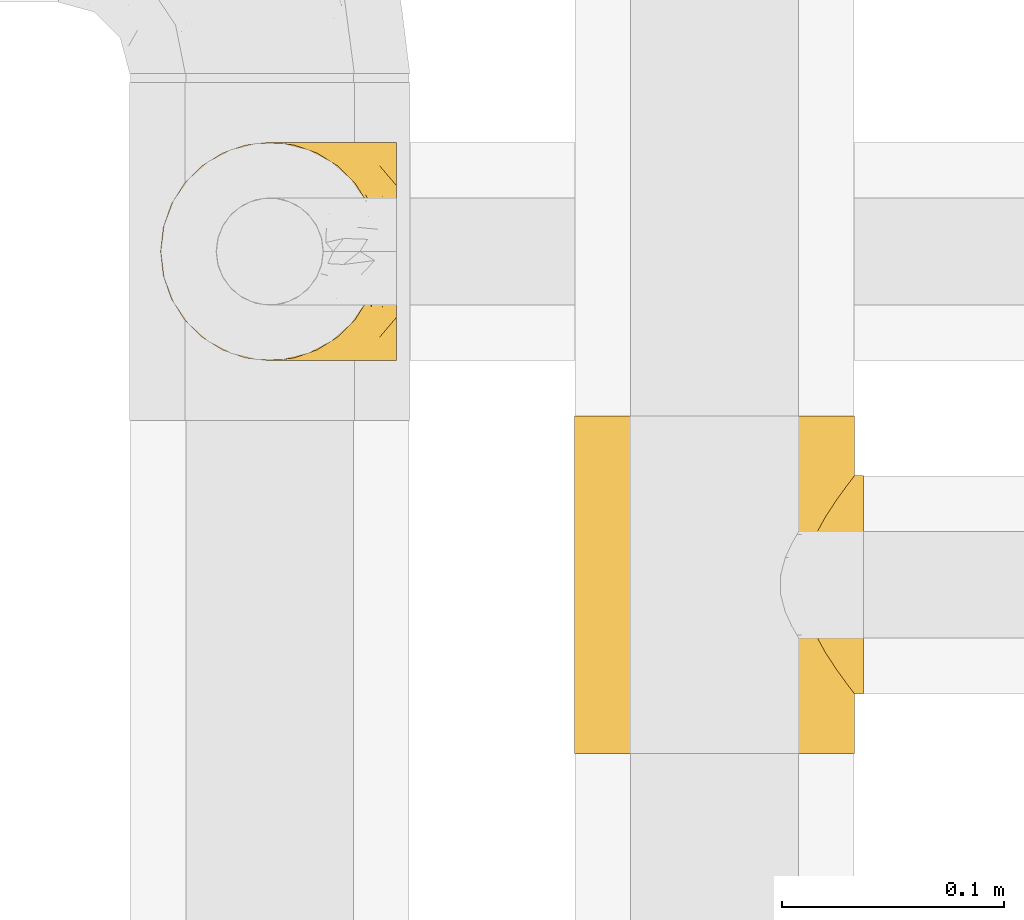
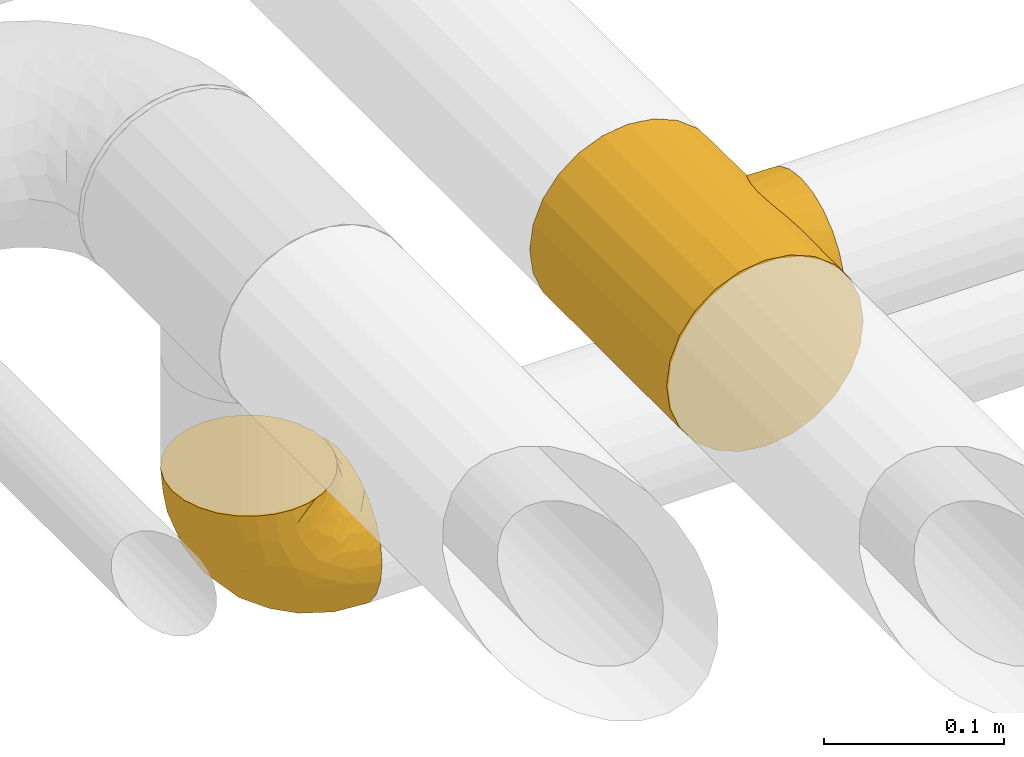
# One storey, part 404 of 827: 2 coverings.
"""IFC2X3 building model written with IfcOpenShell, lengths in millimetres."""

from ifc_helpers import new_model, entity, si_unit, converted_unit, derived_unit, direction, frame, origin, place, context, subcontext, project, spatial, faceted_brep, element, save


model = new_model("IFC2X3")

# Units and contexts
model_context = context("Model", 3, precision=0.01, world=origin(), true_north=direction((6.12303176911189e-17, 1.0)))
body_context = subcontext(model_context, "Body", "Model", "MODEL_VIEW")
ifc_project = project(units=[si_unit("LENGTHUNIT", "METRE", prefix="MILLI"), si_unit("AREAUNIT", "SQUARE_METRE"), si_unit("VOLUMEUNIT", "CUBIC_METRE"), converted_unit("PLANEANGLEUNIT", "DEGREE", entity("IfcRatioMeasure", 0.0174532925199433), si_unit("PLANEANGLEUNIT", "RADIAN"), dimensions=[0, 0, 0, 0, 0, 0, 0]), si_unit("MASSUNIT", "GRAM", prefix="KILO"), derived_unit("MASSDENSITYUNIT", [(si_unit("MASSUNIT", "GRAM", prefix="KILO"), 1), (si_unit("LENGTHUNIT", "METRE"), -3)]), derived_unit("MOMENTOFINERTIAUNIT", [(si_unit("LENGTHUNIT", "METRE"), 4)]), si_unit("TIMEUNIT", "SECOND"), si_unit("FREQUENCYUNIT", "HERTZ"), si_unit("THERMODYNAMICTEMPERATUREUNIT", "DEGREE_CELSIUS"), derived_unit("THERMALTRANSMITTANCEUNIT", [(si_unit("MASSUNIT", "GRAM", prefix="KILO"), 1), (si_unit("THERMODYNAMICTEMPERATUREUNIT", "KELVIN"), -1), (si_unit("TIMEUNIT", "SECOND"), -3)]), derived_unit("VOLUMETRICFLOWRATEUNIT", [(si_unit("LENGTHUNIT", "METRE"), 3), (si_unit("TIMEUNIT", "SECOND"), -1)]), derived_unit("MASSFLOWRATEUNIT", [(si_unit("MASSUNIT", "GRAM", prefix="KILO"), 1), (si_unit("TIMEUNIT", "SECOND"), -1)]), derived_unit("ROTATIONALFREQUENCYUNIT", [(si_unit("TIMEUNIT", "SECOND"), -1)]), si_unit("ELECTRICCURRENTUNIT", "AMPERE"), si_unit("ELECTRICVOLTAGEUNIT", "VOLT"), si_unit("POWERUNIT", "WATT"), si_unit("FORCEUNIT", "NEWTON", prefix="KILO"), si_unit("ILLUMINANCEUNIT", "LUX"), si_unit("LUMINOUSFLUXUNIT", "LUMEN"), si_unit("LUMINOUSINTENSITYUNIT", "CANDELA"), derived_unit("USERDEFINED", [(si_unit("MASSUNIT", "GRAM", prefix="KILO"), -1), (si_unit("LENGTHUNIT", "METRE"), -2), (si_unit("TIMEUNIT", "SECOND"), 3), (si_unit("LUMINOUSFLUXUNIT", "LUMEN"), 1)]), derived_unit("LINEARVELOCITYUNIT", [(si_unit("LENGTHUNIT", "METRE"), 1), (si_unit("TIMEUNIT", "SECOND"), -1)]), si_unit("PRESSUREUNIT", "PASCAL"), derived_unit("USERDEFINED", [(si_unit("LENGTHUNIT", "METRE"), -2), (si_unit("MASSUNIT", "GRAM", prefix="KILO"), 1), (si_unit("TIMEUNIT", "SECOND"), -2)]), derived_unit("LINEARFORCEUNIT", [(si_unit("MASSUNIT", "GRAM", prefix="KILO"), 1), (si_unit("LENGTHUNIT", "METRE"), 1), (si_unit("TIMEUNIT", "SECOND"), -2), (si_unit("LENGTHUNIT", "METRE"), -1)]), derived_unit("PLANARFORCEUNIT", [(si_unit("MASSUNIT", "GRAM", prefix="KILO"), 1), (si_unit("LENGTHUNIT", "METRE"), 1), (si_unit("TIMEUNIT", "SECOND"), -2), (si_unit("LENGTHUNIT", "METRE"), -2)])], contexts=[model_context])

# Site, building, storey
site_placement = place(None, origin())
site = spatial("IfcSite", under=ifc_project, at=site_placement, CompositionType="ELEMENT")
building_placement = place(site_placement, origin())
building = spatial("IfcBuilding", under=site, at=building_placement, CompositionType="ELEMENT")
storey_placement = place(building_placement, frame((0.0, 0.0, 28200.0)))
storey = spatial("IfcBuildingStorey", under=building, at=storey_placement, Name="08", CompositionType="ELEMENT", Elevation=28200.0)

# Coverings
covering_1_placement = place(storey_placement, frame((48594.1, 18129.78, 2749.25)))
element("IfcCovering", 1, at=covering_1_placement, inside=storey, Name=":ADSK_", ObjectType=":ADSK_", PredefinedType="INSULATION", context=body_context, shape_type="Brep", body=[
    faceted_brep([(50.75, 99.9, 107.75), (39.8, 98.66, 107.75), (29.41, 95.02, 107.75), (20.09, 89.17, 107.75), (12.31, 81.38, 107.75), (6.46, 72.06, 107.75), (2.83, 61.68, 107.75), (1.6, 50.75, 107.75), (2.83, 39.8, 107.75), (6.47, 29.41, 107.75), (12.32, 20.09, 107.75), (20.11, 12.31, 107.75), (29.43, 6.46, 107.75), (39.81, 2.83, 107.75), (50.75, 1.6, 107.75), (56.45, 2.24, 107.75), (61.69, 2.83, 107.75), (66.88, 4.65, 107.75), (72.08, 6.47, 107.75), (81.4, 12.32, 107.75), (89.18, 20.11, 107.75), (95.03, 29.43, 107.75), (98.66, 39.81, 107.75), (99.9, 50.75, 107.75), (98.66, 61.69, 107.75), (95.02, 72.08, 107.75), (89.17, 81.4, 107.75), (81.38, 89.18, 107.75), (72.06, 95.03, 107.75), (66.87, 96.85, 107.75), (61.68, 98.66, 107.75), (56.45, 99.25, 107.75), (53.6, 99.57, 107.75), (107.75, 38.02, 98.22), (107.75, 26.17, 93.31), (107.75, 21.08, 89.4), (107.75, 15.99, 85.5), (107.75, 12.09, 80.41), (107.75, 8.18, 75.32), (107.75, 5.73, 69.39), (107.75, 3.27, 63.47), (107.75, 2.35, 56.48), (107.75, 1.97, 53.61), (107.75, 1.6, 50.75), (107.75, 3.27, 38.02), (107.75, 8.18, 26.17), (107.75, 15.99, 15.99), (107.75, 26.17, 8.18), (107.75, 38.02, 3.27), (107.75, 50.75, 1.6), (107.75, 63.47, 3.27), (107.75, 75.32, 8.18), (107.75, 85.5, 15.99), (107.75, 93.31, 26.17), (107.75, 98.22, 38.02), (107.75, 99.9, 50.75), (107.75, 99.14, 56.48), (107.75, 98.22, 63.47), (107.75, 95.77, 69.39), (107.75, 93.31, 75.32), (107.75, 89.4, 80.41), (107.75, 85.5, 85.5), (107.75, 80.41, 89.4), (107.75, 75.32, 93.31), (107.75, 63.47, 98.22), (107.75, 50.75, 99.9), (39.38, 59.31, 27.53), (49.75, 73.08, 25.32), (57.38, 63.72, 16.29), (74.94, 50.75, 6.79), (85.97, 58.64, 4.51), (95.66, 50.75, 3.51), (67.82, 76.74, 17.47), (83.09, 67.68, 7.6), (89.16, 78.92, 12.27), (37.01, 94.31, 70.89), (43.46, 98.76, 87.17), (51.79, 98.4, 67.3), (85.58, 94.57, 31.65), (62.84, 89.91, 33.58), (62.77, 96.32, 47.23), (88.17, 98.79, 43.26), (85.93, 99.9, 55.08), (91.42, 99.9, 53.99), (96.91, 99.9, 52.9), (99.62, 99.9, 52.36), (102.33, 99.9, 51.82), (82.57, 87.31, 21.5), (32.75, 95.61, 89.94), (13.79, 60.43, 60.45), (6.77, 65.24, 83.0), (16.46, 72.87, 64.79), (55.08, 99.9, 85.93), (58.17, 99.9, 81.31), (61.26, 99.9, 76.69), (64.35, 99.9, 72.06), (67.44, 99.9, 67.44), (24.18, 90.65, 88.74), (23.37, 63.14, 45.98), (49.76, 91.89, 47.13), (9.84, 75.25, 89.4), (3.51, 50.75, 95.66), (55.75, 82.18, 28.5), (42.34, 85.08, 42.81), (37.78, 76.93, 38.28), (21.87, 50.75, 45.35), (33.61, 50.75, 33.61), (17.1, 83.02, 82.57), (51.28, 99.9, 105.04), (51.82, 99.9, 102.33), (52.9, 99.9, 96.91), (53.99, 99.9, 91.42), (28.01, 87.13, 65.92), (28.99, 80.85, 53.11), (69.9, 99.17, 54.37), (6.79, 50.75, 74.94), (72.06, 99.9, 64.35), (76.69, 99.9, 61.26), (81.31, 99.9, 58.17), (45.35, 50.75, 21.87), (34.79, 67.61, 34.79), (25.72, 72.25, 48.48), (14.33, 50.75, 60.15), (60.15, 50.75, 14.33), (62.38, 98.69, 99.07), (100.57, 99.01, 60.55), (91.06, 98.79, 64.18), (97.66, 98.29, 64.36), (97.55, 68.51, 103.17), (93.65, 76.82, 101.69), (66.85, 98.54, 87.75), (61.93, 99.3, 89.38), (101.4, 83.57, 88.34), (100.07, 89.47, 82.14), (101.36, 75.76, 94.51), (95.94, 84.86, 89.64), (96.3, 75.89, 98.41), (101.98, 64.77, 99.71), (85.88, 90.83, 89.37), (78.88, 94.62, 88.21), (82.8, 90.37, 95.2), (102.58, 91.18, 79.14), (82.88, 88.65, 101.22), (88.57, 84.11, 99.41), (88.67, 91.75, 84.72), (69.08, 96.86, 97.47), (102.19, 50.75, 102.19), (100.06, 58.97, 104.02), (70.56, 98.37, 82.66), (91.07, 83.91, 95.42), (77.56, 97.52, 78.67), (96.59, 95.55, 72.69), (86.38, 98.76, 66.46), (91.79, 95.26, 75.3), (81.71, 98.04, 72.74), (94.11, 90.65, 82.93), (76.09, 93.51, 99.27), (76.91, 94.16, 93.51), (81.44, 99.1, 67.35), (101.37, 25.73, 94.51), (94.12, 10.84, 82.94), (101.41, 17.92, 88.33), (95.96, 16.64, 89.64), (96.22, 30.44, 103.62), (66.85, 2.95, 87.74), (61.94, 2.19, 89.38), (58.17, 1.6, 81.31), (69.1, 4.63, 97.47), (88.58, 17.39, 99.41), (96.91, 1.6, 52.9), (102.33, 1.6, 51.82), (105.04, 1.6, 51.28), (82.9, 12.86, 101.21), (82.82, 11.13, 95.19), (97.66, 3.2, 64.36), (96.59, 5.94, 72.69), (100.07, 12.02, 82.13), (91.79, 6.23, 75.3), (102.58, 10.31, 79.14), (76.13, 8.0, 99.28), (76.93, 7.34, 93.51), (100.57, 2.48, 60.55), (86.38, 2.73, 66.46), (90.86, 2.64, 63.96), (52.9, 1.6, 96.91), (62.39, 2.8, 99.06), (101.98, 36.71, 99.7), (91.42, 1.6, 53.99), (85.93, 1.6, 55.08), (99.49, 38.59, 103.3), (51.82, 1.6, 102.33), (52.36, 1.6, 99.62), (61.26, 1.6, 76.69), (70.56, 3.12, 82.66), (91.09, 17.59, 95.42), (64.35, 1.6, 72.06), (77.6, 3.98, 78.68), (78.89, 6.87, 88.2), (81.71, 3.45, 72.75), (88.69, 9.76, 84.74), (53.99, 1.6, 91.42), (55.08, 1.6, 85.93), (96.31, 25.62, 98.41), (85.9, 10.67, 89.37), (81.45, 2.39, 67.35), (76.69, 1.6, 61.26), (81.31, 1.6, 58.17), (72.06, 1.6, 64.35), (67.44, 1.6, 67.44), (69.6, 2.4, 54.08), (85.97, 42.85, 4.51), (82.57, 14.18, 21.5), (63.16, 11.56, 33.43), (55.81, 19.27, 28.5), (67.81, 24.75, 17.47), (49.73, 28.37, 25.36), (32.55, 5.95, 90.18), (43.23, 2.79, 86.97), (88.17, 2.71, 43.26), (57.38, 37.78, 16.29), (83.08, 33.81, 7.6), (89.16, 22.57, 12.27), (85.58, 6.92, 31.65), (16.46, 28.61, 64.79), (6.77, 36.24, 83.0), (13.8, 41.05, 60.44), (37.71, 24.55, 38.35), (34.8, 33.88, 34.8), (36.83, 7.11, 71.54), (39.38, 42.18, 27.53), (17.12, 18.46, 82.57), (24.19, 10.84, 88.74), (28.89, 20.69, 53.19), (25.69, 29.27, 48.49), (51.77, 3.1, 67.28), (45.66, 9.18, 52.32), (23.39, 38.38, 45.94), (9.85, 26.23, 89.4), (28.11, 14.34, 65.75), (62.27, 5.46, 46.73), (42.35, 16.39, 42.82)], [[[0, 1, 2, 3, 4, 5, 6, 7, 8, 9, 10, 11, 12, 13, 14, 15, 16, 17, 18, 19, 20, 21, 22, 23, 24, 25, 26, 27, 28, 29, 30, 31, 32]], [[33, 34, 35, 36, 37, 38, 39, 40, 41, 42, 43, 44, 45, 46, 47, 48, 49, 50, 51, 52, 53, 54, 55, 56, 57, 58, 59, 60, 61, 62, 63, 64, 65]], [[66, 67, 68]], [[69, 70, 71]], [[68, 72, 73]], [[73, 72, 74]], [[75, 76, 77]], [[78, 79, 80]], [[51, 50, 73]], [[81, 82, 83, 84, 85, 86, 55]], [[52, 87, 53]], [[74, 52, 51]], [[2, 1, 88]], [[89, 90, 91]], [[77, 92, 93, 94, 95, 96]], [[55, 54, 81]], [[78, 53, 87]], [[5, 90, 6]], [[88, 76, 75]], [[97, 3, 2]], [[89, 91, 98]], [[99, 80, 79]], [[90, 5, 100]], [[74, 87, 52]], [[100, 5, 4]], [[90, 101, 6]], [[79, 102, 103]], [[102, 67, 104]], [[105, 98, 106]], [[107, 4, 3]], [[76, 0, 108, 109, 110, 111, 92]], [[107, 112, 113]], [[114, 77, 96]], [[89, 115, 90]], [[114, 96, 116, 117, 118, 82]], [[75, 97, 88]], [[119, 66, 68]], [[50, 71, 70]], [[100, 91, 90]], [[99, 77, 80]], [[102, 104, 103]], [[97, 107, 3]], [[80, 81, 78]], [[107, 97, 112]], [[68, 73, 70]], [[66, 98, 120]], [[78, 81, 54]], [[114, 81, 80]], [[53, 78, 54]], [[78, 87, 79]], [[102, 87, 72]], [[79, 103, 99]], [[4, 107, 100]], [[91, 100, 107]], [[88, 97, 2]], [[112, 97, 75]], [[99, 112, 75]], [[103, 104, 113]], [[91, 121, 98]], [[89, 105, 122, 115]], [[101, 90, 115]], [[101, 7, 6]], [[88, 1, 76]], [[0, 76, 1]], [[92, 77, 76]], [[73, 74, 51]], [[87, 74, 72]], [[81, 114, 82]], [[77, 114, 80]], [[87, 102, 79]], [[67, 102, 72]], [[68, 67, 72]], [[67, 120, 104]], [[120, 121, 104]], [[104, 121, 113]], [[121, 120, 98]], [[91, 107, 113]], [[91, 113, 121]], [[103, 113, 112]], [[106, 98, 66]], [[105, 89, 98]], [[106, 66, 119]], [[67, 66, 120]], [[68, 69, 123, 119]], [[50, 49, 71]], [[50, 70, 73]], [[112, 99, 103]], [[77, 99, 75]], [[69, 68, 70]], [[29, 124, 110]], [[84, 83, 125]], [[126, 82, 118]], [[59, 58, 127]], [[25, 128, 129]], [[130, 93, 131]], [[132, 62, 133]], [[134, 135, 136]], [[137, 65, 64]], [[64, 134, 137]], [[138, 139, 140]], [[111, 110, 124, 92]], [[134, 136, 137]], [[134, 64, 63]], [[141, 61, 60]], [[125, 58, 57]], [[142, 143, 140]], [[142, 26, 143]], [[127, 83, 82]], [[28, 124, 29]], [[108, 0, 32, 31, 30, 110, 109]], [[30, 29, 110]], [[135, 144, 138]], [[28, 145, 124]], [[57, 56, 55, 86, 85, 84]], [[146, 147, 23]], [[24, 23, 147]], [[25, 143, 26]], [[95, 94, 148]], [[24, 128, 25]], [[149, 138, 143]], [[124, 145, 131]], [[127, 58, 125]], [[150, 148, 139]], [[127, 126, 151]], [[151, 59, 127]], [[152, 151, 126]], [[153, 154, 155]], [[153, 133, 141]], [[145, 28, 27]], [[142, 156, 27]], [[157, 148, 130]], [[61, 133, 62]], [[134, 132, 135]], [[147, 128, 24]], [[65, 137, 146]], [[146, 137, 147]], [[128, 137, 136]], [[137, 128, 147]], [[128, 136, 129]], [[149, 129, 136]], [[25, 129, 143]], [[158, 152, 117]], [[152, 118, 117]], [[153, 151, 152]], [[158, 116, 154]], [[144, 150, 138]], [[153, 152, 158]], [[133, 153, 155]], [[133, 155, 132]], [[60, 151, 141]], [[135, 132, 155]], [[134, 63, 132]], [[144, 135, 155]], [[135, 138, 149]], [[155, 154, 144]], [[150, 154, 96]], [[154, 150, 144]], [[148, 94, 130]], [[82, 126, 127]], [[118, 152, 126]], [[150, 96, 95]], [[139, 148, 157]], [[150, 95, 148]], [[93, 92, 131]], [[130, 145, 156]], [[130, 94, 93]], [[84, 125, 57]], [[127, 125, 83]], [[140, 139, 157]], [[150, 139, 138]], [[140, 157, 142]], [[138, 140, 143]], [[156, 142, 157]], [[27, 26, 142]], [[130, 156, 157]], [[145, 27, 156]], [[132, 63, 62]], [[124, 131, 92]], [[130, 131, 145]], [[129, 149, 143]], [[135, 149, 136]], [[141, 133, 61]], [[60, 59, 151]], [[141, 151, 153]], [[116, 96, 154]], [[153, 158, 154]], [[158, 117, 116]], [[34, 33, 159]], [[160, 161, 162]], [[22, 21, 163]], [[164, 165, 166]], [[19, 18, 167]], [[168, 21, 20]], [[42, 41, 40, 169, 170, 171, 43]], [[172, 173, 168]], [[174, 38, 175]], [[176, 177, 178]], [[179, 164, 180]], [[40, 181, 169]], [[182, 183, 175]], [[17, 184, 185]], [[65, 146, 186]], [[187, 174, 188]], [[23, 22, 189]], [[174, 39, 38]], [[15, 14, 190, 191, 184, 16]], [[181, 40, 39]], [[192, 193, 164]], [[194, 163, 168]], [[33, 186, 159]], [[180, 173, 172]], [[195, 196, 193]], [[18, 185, 167]], [[173, 180, 197]], [[198, 199, 196]], [[200, 201, 185, 184]], [[184, 17, 16]], [[18, 17, 185]], [[202, 159, 186]], [[194, 168, 203]], [[189, 163, 202]], [[204, 205, 182]], [[187, 181, 174]], [[160, 177, 176]], [[206, 183, 182]], [[206, 182, 205]], [[201, 165, 185]], [[165, 164, 167]], [[172, 179, 180]], [[202, 194, 162]], [[176, 161, 160]], [[65, 186, 33]], [[163, 189, 22]], [[175, 177, 182]], [[174, 183, 188]], [[177, 198, 204]], [[199, 160, 162]], [[198, 207, 204]], [[175, 38, 37]], [[198, 177, 160]], [[178, 177, 175]], [[176, 35, 161]], [[34, 159, 161]], [[162, 161, 159]], [[202, 162, 159]], [[199, 162, 203]], [[196, 199, 203]], [[198, 160, 199]], [[193, 197, 180]], [[208, 198, 196]], [[188, 183, 206]], [[175, 183, 174]], [[193, 192, 195]], [[195, 208, 196]], [[197, 196, 203]], [[180, 164, 193]], [[168, 163, 21]], [[166, 165, 201]], [[166, 192, 164]], [[189, 202, 186]], [[186, 146, 189]], [[23, 189, 146]], [[174, 181, 39]], [[169, 181, 187]], [[196, 197, 193]], [[173, 203, 168]], [[203, 173, 197]], [[172, 168, 20]], [[20, 19, 172]], [[179, 172, 19]], [[19, 167, 179]], [[164, 179, 167]], [[35, 176, 36]], [[35, 34, 161]], [[185, 165, 167]], [[162, 194, 203]], [[163, 194, 202]], [[176, 178, 36]], [[37, 36, 178]], [[175, 37, 178]], [[177, 204, 182]], [[207, 198, 208]], [[207, 205, 204]], [[209, 188, 206, 205, 207, 208]], [[48, 210, 71]], [[211, 212, 213]], [[214, 213, 215]], [[216, 217, 13]], [[218, 43, 171, 170, 169, 187, 188]], [[219, 220, 214]], [[47, 46, 221]], [[210, 48, 220]], [[211, 222, 212]], [[222, 45, 44]], [[221, 220, 47]], [[47, 220, 48]], [[221, 211, 214]], [[223, 224, 225]], [[211, 46, 45]], [[226, 227, 215]], [[43, 218, 44]], [[217, 216, 228]], [[219, 215, 229]], [[14, 13, 217]], [[224, 9, 8]], [[10, 230, 11]], [[11, 231, 12]], [[232, 223, 233]], [[234, 208, 195, 192, 166, 201]], [[235, 234, 228]], [[222, 44, 218]], [[106, 229, 236]], [[224, 237, 9]], [[231, 238, 228]], [[9, 237, 10]], [[115, 224, 101]], [[239, 234, 235]], [[231, 11, 230]], [[223, 230, 237]], [[224, 8, 101]], [[223, 236, 233]], [[225, 115, 122, 105]], [[216, 12, 231]], [[209, 234, 239]], [[210, 219, 69]], [[219, 214, 215]], [[229, 119, 219]], [[209, 218, 188]], [[239, 212, 222]], [[239, 222, 218]], [[45, 222, 211]], [[235, 212, 239]], [[213, 212, 240]], [[223, 237, 224]], [[230, 10, 237]], [[238, 231, 230]], [[216, 231, 228]], [[232, 230, 223]], [[235, 238, 240]], [[115, 225, 224]], [[233, 236, 227]], [[8, 7, 101]], [[234, 209, 208]], [[218, 209, 239]], [[217, 228, 234]], [[13, 12, 216]], [[234, 201, 217]], [[217, 201, 200, 184, 191, 190, 14]], [[211, 221, 46]], [[220, 221, 214]], [[71, 210, 69]], [[71, 49, 48]], [[219, 210, 220]], [[226, 215, 213]], [[211, 213, 214]], [[226, 213, 240]], [[215, 227, 229]], [[232, 240, 238]], [[233, 227, 226]], [[232, 233, 226]], [[236, 223, 225]], [[240, 232, 226]], [[232, 238, 230]], [[225, 105, 236]], [[236, 105, 106]], [[236, 229, 227]], [[123, 69, 219, 119]], [[106, 119, 229]], [[238, 235, 228]], [[212, 235, 240]]]),
])
covering_2_placement = place(storey_placement, frame((48780.39, 17954.53, 2935.35)))
element("IfcCovering", 2, at=covering_2_placement, inside=storey, Name=":ADSK_", ObjectType=":ADSK_", PredefinedType="INSULATION", context=body_context, shape_type="Brep", body=[
    faceted_brep([(10.04, 152.0, 33.12), (3.74, 152.0, 48.33), (1.6, 152.0, 64.65), (3.74, 152.0, 80.96), (10.04, 152.0, 96.17), (20.06, 152.0, 109.23), (33.12, 152.0, 119.25), (48.33, 152.0, 125.55), (64.65, 152.0, 127.7), (80.96, 152.0, 125.55), (96.17, 152.0, 119.25), (109.23, 152.0, 109.23), (114.24, 152.0, 102.7), (119.25, 152.0, 96.17), (122.4, 152.0, 88.57), (125.55, 152.0, 80.96), (126.62, 152.0, 72.8), (127.7, 152.0, 64.65), (126.62, 152.0, 56.49), (125.55, 152.0, 48.33), (122.4, 152.0, 40.72), (119.25, 152.0, 33.12), (114.24, 152.0, 26.59), (109.23, 152.0, 20.06), (96.17, 152.0, 10.04), (80.96, 152.0, 3.74), (64.65, 152.0, 1.6), (48.33, 152.0, 3.74), (33.12, 152.0, 10.04), (20.06, 152.0, 20.06), (64.65, 0.0, 127.7), (48.33, 0.0, 125.55), (33.12, 0.0, 119.25), (20.06, 0.0, 109.23), (10.04, 0.0, 96.17), (3.74, 0.0, 80.96), (1.6, 0.0, 64.65), (3.74, 0.0, 48.33), (10.04, 0.0, 33.12), (20.06, 0.0, 20.06), (33.12, 0.0, 10.04), (48.33, 0.0, 3.74), (64.65, 0.0, 1.6), (80.96, 0.0, 3.74), (96.17, 0.0, 10.04), (109.23, 0.0, 20.06), (114.24, 0.0, 26.59), (119.25, 0.0, 33.12), (122.4, 0.0, 40.72), (125.55, 0.0, 48.33), (126.62, 0.0, 56.49), (127.7, 0.0, 64.65), (126.62, 0.0, 72.8), (125.55, 0.0, 80.96), (122.4, 0.0, 88.57), (119.25, 0.0, 96.17), (114.24, 0.0, 102.7), (109.23, 0.0, 109.23), (96.17, 0.0, 119.25), (80.96, 0.0, 125.55), (114.58, 45.43, 103.13), (109.69, 54.33, 108.76), (119.49, 37.94, 95.74), (123.72, 119.94, 86.67), (105.75, 64.61, 112.46), (104.14, 76.0, 113.8), (105.75, 87.39, 112.46), (127.17, 124.47, 70.38), (127.7, 125.15, 64.65), (127.7, 26.85, 64.65), (127.17, 27.53, 70.38), (114.58, 106.57, 103.13), (109.69, 97.67, 108.76), (119.49, 114.06, 95.74), (123.72, 32.06, 86.67), (125.18, 121.87, 81.39), (126.64, 123.79, 76.12), (126.64, 28.21, 76.12), (125.18, 30.13, 81.39), (127.17, 27.53, 58.91), (126.64, 28.21, 53.17), (119.49, 37.94, 33.55), (123.72, 32.06, 42.62), (125.18, 30.13, 47.9), (126.64, 123.79, 53.17), (127.17, 124.47, 58.91), (119.49, 114.06, 33.55), (123.72, 119.94, 42.62), (114.58, 106.57, 26.16), (125.18, 121.87, 47.9), (114.58, 45.43, 26.16), (109.69, 54.33, 20.53), (105.75, 64.61, 16.83), (104.14, 76.0, 15.5), (109.69, 97.67, 20.53), (105.75, 87.39, 16.83), (131.65, 63.28, 112.12), (131.65, 51.42, 107.21), (131.65, 41.25, 99.4), (131.65, 33.43, 89.22), (131.65, 30.98, 83.29), (131.65, 28.52, 77.37), (131.65, 27.69, 71.01), (131.65, 26.85, 64.65), (131.65, 27.69, 58.28), (131.65, 28.52, 51.92), (131.65, 30.98, 46.0), (131.65, 33.43, 40.07), (131.65, 41.25, 29.89), (131.65, 51.42, 22.08), (131.65, 63.28, 17.17), (131.65, 76.0, 15.5), (131.65, 88.72, 17.17), (131.65, 100.57, 22.08), (131.65, 110.75, 29.89), (131.65, 118.57, 40.07), (131.65, 121.02, 46.0), (131.65, 123.48, 51.92), (131.65, 124.31, 58.28), (131.65, 125.15, 64.65), (131.65, 124.31, 71.01), (131.65, 123.48, 77.37), (131.65, 121.02, 83.29), (131.65, 118.57, 89.22), (131.65, 110.75, 99.4), (131.65, 100.57, 107.21), (131.65, 88.72, 112.12), (131.65, 76.0, 113.8)], [[[0, 1, 2, 3, 4, 5, 6, 7, 8, 9, 10, 11, 12, 13, 14, 15, 16, 17, 18, 19, 20, 21, 22, 23, 24, 25, 26, 27, 28, 29]], [[30, 31, 32, 33, 34, 35, 36, 37, 38, 39, 40, 41, 42, 43, 44, 45, 46, 47, 48, 49, 50, 51, 52, 53, 54, 55, 56, 57, 58, 59]], [[34, 33, 5, 4]], [[2, 36, 35, 3]], [[4, 3, 35, 34]], [[6, 32, 31, 7]], [[7, 31, 30, 8]], [[5, 33, 32, 6]], [[59, 9, 8, 30]], [[58, 10, 9, 59]], [[57, 60, 61]], [[56, 55, 62]], [[63, 15, 14]], [[61, 64, 57]], [[60, 57, 56]], [[57, 64, 58]], [[64, 65, 58]], [[66, 11, 10]], [[17, 67, 68]], [[69, 70, 51]], [[71, 11, 72]], [[72, 11, 66]], [[73, 12, 71]], [[66, 10, 65]], [[65, 10, 58]], [[62, 54, 74]], [[54, 62, 55]], [[74, 54, 53]], [[15, 63, 75, 76]], [[77, 53, 52]], [[51, 70, 52]], [[77, 52, 70]], [[53, 77, 78, 74]], [[73, 13, 12]], [[73, 14, 13]], [[14, 73, 63]], [[16, 76, 67]], [[71, 12, 11]], [[17, 16, 67]], [[16, 15, 76]], [[60, 56, 62]], [[50, 79, 51]], [[80, 50, 49]], [[47, 81, 48]], [[82, 48, 81]], [[82, 49, 48]], [[49, 82, 83, 80]], [[50, 80, 79]], [[84, 18, 85]], [[85, 17, 68]], [[51, 79, 69]], [[86, 21, 20]], [[17, 85, 18]], [[20, 19, 87]], [[86, 88, 22]], [[87, 19, 84, 89]], [[81, 46, 90]], [[81, 47, 46]], [[90, 45, 91]], [[45, 90, 46]], [[91, 45, 92]], [[24, 44, 43, 25]], [[93, 92, 44]], [[44, 92, 45]], [[43, 42, 26, 25]], [[84, 19, 18]], [[94, 95, 23]], [[86, 20, 87]], [[22, 21, 86]], [[23, 88, 94]], [[95, 24, 23]], [[93, 24, 95]], [[93, 44, 24]], [[88, 23, 22]], [[27, 41, 40, 28]], [[28, 40, 39, 29]], [[42, 41, 27, 26]], [[0, 38, 37, 1]], [[1, 37, 36, 2]], [[29, 39, 38, 0]], [[96, 97, 98, 99, 100, 101, 102, 103, 104, 105, 106, 107, 108, 109, 110, 111, 112, 113, 114, 115, 116, 117, 118, 119, 120, 121, 122, 123, 124, 125, 126, 127]], [[77, 102, 101]], [[74, 100, 99]], [[103, 70, 69]], [[103, 102, 70]], [[101, 78, 77]], [[62, 74, 99]], [[100, 78, 101]], [[100, 74, 78]], [[99, 98, 62]], [[60, 98, 97]], [[96, 127, 64]], [[102, 77, 70]], [[61, 97, 96]], [[60, 97, 61]], [[64, 61, 96]], [[65, 64, 127]], [[98, 60, 62]], [[66, 127, 126]], [[72, 126, 125]], [[65, 127, 66]], [[119, 67, 120]], [[66, 126, 72]], [[125, 71, 72]], [[125, 124, 71]], [[73, 124, 123]], [[76, 75, 121]], [[67, 119, 68]], [[76, 121, 120]], [[63, 73, 123]], [[63, 123, 122]], [[76, 120, 67]], [[122, 75, 63]], [[121, 75, 122]], [[124, 73, 71]], [[84, 118, 117]], [[87, 116, 115]], [[119, 85, 68]], [[119, 118, 85]], [[117, 89, 84]], [[86, 87, 115]], [[116, 89, 117]], [[118, 84, 85]], [[115, 114, 86]], [[88, 114, 113]], [[113, 112, 94]], [[111, 95, 112]], [[116, 87, 89]], [[88, 113, 94]], [[95, 94, 112]], [[93, 95, 111]], [[114, 88, 86]], [[92, 111, 110]], [[91, 110, 109]], [[93, 111, 92]], [[103, 79, 104]], [[92, 110, 91]], [[109, 90, 91]], [[109, 108, 90]], [[81, 108, 107]], [[80, 83, 105]], [[79, 103, 69]], [[80, 105, 104]], [[82, 81, 107]], [[82, 107, 106]], [[80, 104, 79]], [[106, 83, 82]], [[105, 83, 106]], [[108, 81, 90]]]),
])

save(model, "model.ifc")
